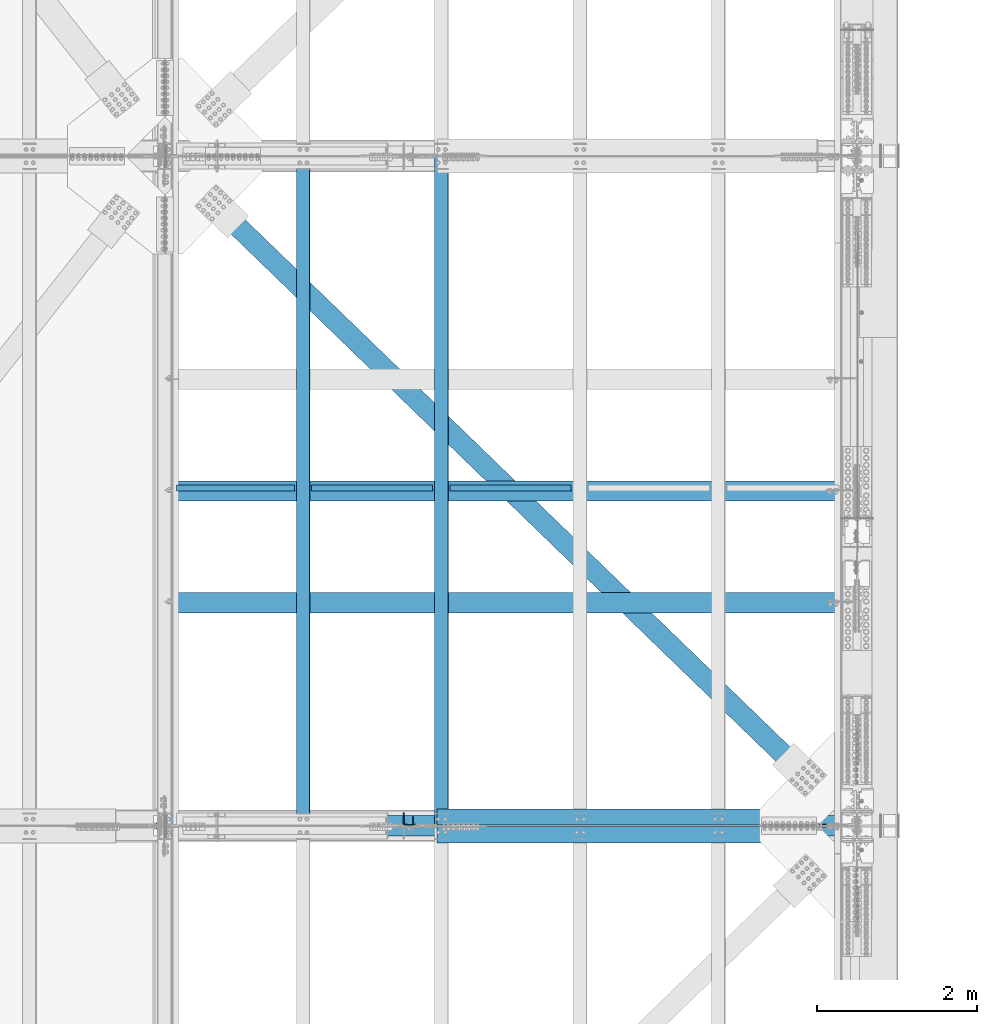
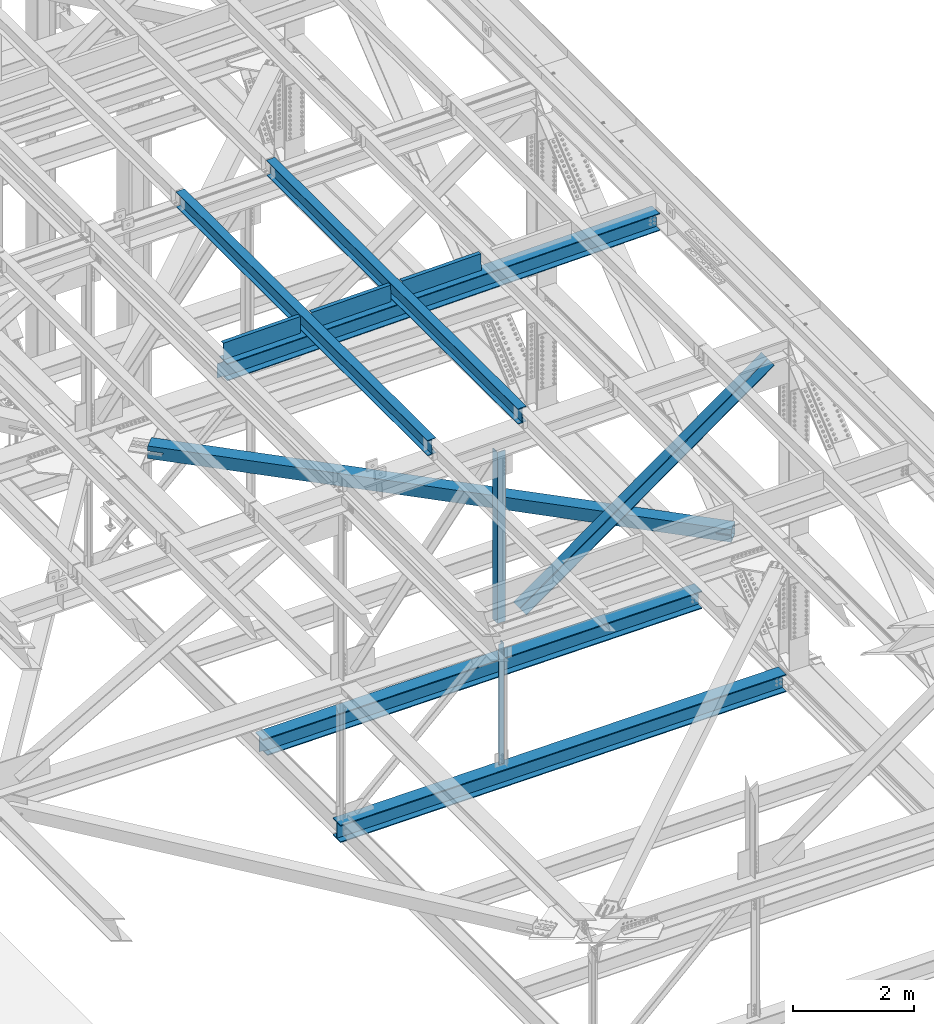
# One storey, part 1976 of 3843: 11 beams, 2 members, 13 elements without a shape of their own.
"""IFC2X3 building model written with IfcOpenShell, lengths in millimetres."""

from ifc_helpers import new_model, si_unit, frame, origin_with_axes, place, context, subcontext, project, spatial, faceted_brep, material, type_object, element, aggregate, save


model = new_model("IFC2X3")

# Units and contexts
model_context = context("Model", 3, precision=1e-05, world=origin_with_axes())
body_context = subcontext(model_context, "Body", "Model", "MODEL_VIEW")
ifc_project = project(units=[si_unit("LENGTHUNIT", "METRE", prefix="MILLI"), si_unit("AREAUNIT", "SQUARE_METRE"), si_unit("VOLUMEUNIT", "CUBIC_METRE"), si_unit("MASSUNIT", "GRAM", prefix="KILO"), si_unit("TIMEUNIT", "SECOND"), si_unit("PLANEANGLEUNIT", "RADIAN"), si_unit("SOLIDANGLEUNIT", "STERADIAN"), si_unit("THERMODYNAMICTEMPERATUREUNIT", "DEGREE_CELSIUS"), si_unit("LUMINOUSINTENSITYUNIT", "LUMEN")], contexts=[model_context])

# Site, building, storey
site_placement = place(None, origin_with_axes())
site = spatial("IfcSite", under=ifc_project, at=site_placement, CompositionType="ELEMENT")
building_placement = place(site_placement, origin_with_axes())
building = spatial("IfcBuilding", under=site, at=building_placement, Name="Undefined", CompositionType="ELEMENT")
storey_placement = place(building_placement, origin_with_axes())
storey = spatial("IfcBuildingStorey", under=building, at=storey_placement, Name="Undefined", CompositionType="ELEMENT", Elevation=0.0)

# Assembly, beam
assembly_1_placement = place(storey_placement, origin_with_axes())
assembly_1 = element("IfcElementAssembly", 1, at=assembly_1_placement, inside=storey, Name="ANGLE", AssemblyPlace="NOTDEFINED", PredefinedType="RIGID_FRAME")
ifc_material_1 = material(Name="STEEL/A572-50")
beam_type_1 = type_object("IfcBeamType", Name="L4X4X3/8", PredefinedType="NOTDEFINED")
beam_1_placement = place(assembly_1_placement, frame((80060.8000000188, 67332.225, 42332.0264524968), z_axis=(-1.0, 0.0, 0.0), x_axis=(0.0, 0.0, -1.0)))
beam_1 = element("IfcBeam", 2, at=beam_1_placement, type_object=beam_type_1, material=ifc_material_1, Name="ANGLE", ObjectType="L4X4X3/8", context=body_context, shape_type="Brep", body=[
    faceted_brep([(217.533433356046, 50.8000000000029, -50.8000000000029), (217.533433356046, 50.8000000000029, 50.8000000000029), (2656.88172797261, 50.8000000000029, 50.8000000000029), (2656.88172797261, 50.8000000000029, -50.8000000000029), (217.533433356046, 41.2749999999942, 50.8000000000029), (2656.88172797261, 41.2749999999942, 50.8000000000029), (217.533433356046, 41.2749999999942, -41.2749999999942), (2656.88172797261, 41.2749999999942, -41.2749999999942), (217.533433356046, -50.8000000000029, -41.2749999999942), (2656.88172797261, -50.8000000000029, -41.2749999999942), (217.533433356046, -50.8000000000029, -50.8000000000029), (2656.88172797261, -50.8000000000029, -50.8000000000029)], [[[0, 1, 2, 3]], [[1, 4, 5, 2]], [[4, 6, 7, 5]], [[6, 8, 9, 7]], [[8, 10, 11, 9]], [[10, 0, 3, 11]], [[5, 7, 9, 11, 3, 2]], [[10, 8, 6, 4, 1, 0]]]),
])
aggregate(assembly_1, [beam_1])

assembly_2_placement = place(storey_placement, origin_with_axes())
assembly_2 = element("IfcElementAssembly", 3, at=assembly_2_placement, inside=storey, Name="BEAM", AssemblyPlace="NOTDEFINED", PredefinedType="RIGID_FRAME")
ifc_material_2 = material(Name="STEEL/A992")
beam_type_2 = type_object("IfcBeamType", Name="W12X26", PredefinedType="NOTDEFINED")
beam_2_placement = place(assembly_2_placement, frame((80463.9094464825, 67272.235581982, 46586.9680416804), z_axis=(-0.021152098224542, 0.00215704300087236, 0.999773942402077), x_axis=(5.99999983432721e-09, 0.999997672538073, -0.00215752599900297)))
beam_2 = element("IfcBeam", 4, at=beam_2_placement, type_object=beam_type_2, material=ifc_material_2, Name="BEAM", ObjectType="W12X26", context=body_context, shape_type="Brep", body=[
    faceted_brep([(12.7037963889888, 82.550000000585, -155.57500000039), (12.6832505025814, 82.550000000585, -146.050000000381), (8343.90264109008, 82.5500000384782, -146.049999975839), (8343.92318697649, 82.5500000384927, -155.574999975855), (12.6796285968449, 3.17500000013388, -146.050000000163), (8343.89901918435, 3.17500003804162, -146.049999975628), (12.04955474702, 3.17500000003201, 146.050000000221), (8343.26894533455, 3.17500003793975, 146.050000024748), (12.0531766527711, 82.5500000004977, 146.049999999996), (8343.27256724026, 82.5500000384054, 146.050000024537), (12.0326307663636, 82.5500000004977, 155.575000000012), (8343.25202135387, 82.5500000383909, 155.575000024546), (12.0250972024223, -82.550000000454, 155.575000000463), (8343.24448778994, -82.5499999625608, 155.575000025005), (12.0456430888298, -82.550000000454, 146.050000000461), (8343.26503367635, -82.5499999625463, 146.050000024989), (12.0492649945663, -3.17500000000291, 146.050000000236), (8343.26865558207, -3.17499996210972, 146.05000002477), (12.6793388443766, -3.1749999999156, -146.050000000141), (8343.89872943189, -3.17499996200786, -146.049999975599), (12.6757169386547, -82.5500000003522, -146.049999999923), (8343.89510752616, -82.549999962459, -146.049999975388), (12.6962628250476, -82.5500000003522, -155.574999999924), (8343.91565341257, -82.5499999624444, -155.574999975397)], [[[0, 1, 2, 3]], [[1, 4, 5, 2]], [[4, 6, 7, 5]], [[6, 8, 9, 7]], [[8, 10, 11, 9]], [[10, 12, 13, 11]], [[12, 14, 15, 13]], [[14, 16, 17, 15]], [[16, 18, 19, 17]], [[18, 20, 21, 19]], [[20, 22, 23, 21]], [[22, 0, 3, 23]], [[5, 7, 9, 11, 13, 15, 17, 19, 21, 23, 3, 2]], [[22, 20, 18, 16, 14, 12, 10, 8, 6, 4, 1, 0]]]),
])
aggregate(assembly_2, [beam_2])

assembly_3_placement = place(storey_placement, origin_with_axes())
assembly_3 = element("IfcElementAssembly", 5, at=assembly_3_placement, inside=storey, Name="BEAM", AssemblyPlace="NOTDEFINED", PredefinedType="RIGID_FRAME")
beam_3_placement = place(assembly_3_placement, frame((78736.709446509, 67272.2368257242, 46553.2797616428), z_axis=(-0.02115209757931, 0.00216448800069338, 0.999773926325192), x_axis=(0.0, 0.999997653701546, -0.00216623899934971)))
beam_3 = element("IfcBeam", 6, at=beam_3_placement, type_object=beam_type_2, material=ifc_material_2, Name="BEAM", ObjectType="W12X26", context=body_context, shape_type="Brep", body=[
    faceted_brep([(12.7037963889888, 82.550000000585, -155.57500000039), (12.683193207602, 82.5500000002357, -146.050000000549), (8343.90271783868, 82.5500000001048, -146.049999994), (8343.92333463172, 82.5500000000757, -155.574999994024), (12.6795583240309, 3.17499999979918, -146.050000000425), (8343.8990829551, 3.17499999965366, -146.049999993877), (12.0471441895206, 3.17500000087603, 146.050000000134), (8343.26667870262, 3.1750000386819, 146.050000029725), (12.0507795210287, 82.5500000013417, 146.049999999879), (8343.27031403412, 82.550000039133, 146.050000029471), (12.0301574891928, 82.5500000013853, 155.574999999881), (8343.2496920023, 82.5500000391767, 155.575000029479), (12.0225959997188, -82.5499999995372, 155.575000000405), (8343.24213051282, -82.5499999617459, 155.575000029996), (12.0432180315256, -82.5499999995955, 146.05000000041), (8343.26275254463, -82.5499999618041, 146.050000030002), (12.0468533630192, -3.17499999914435, 146.050000000156), (8343.26638787612, -3.17499996136758, 146.050000029747), (12.6792675333563, -3.17500000025029, -146.050000000425), (8343.89879216443, -3.17500000038126, -146.049999993869), (12.6756326497853, -82.5500000006869, -146.050000000301), (8343.89516152057, -82.5499999634485, -146.049999970179), (12.6962628250476, -82.5500000003522, -155.574999999924), (8343.9157740739, -82.5500000008324, -155.574999993776)], [[[0, 1, 2, 3]], [[1, 4, 5, 2]], [[4, 6, 7, 5]], [[6, 8, 9, 7]], [[8, 10, 11, 9]], [[10, 12, 13, 11]], [[12, 14, 15, 13]], [[14, 16, 17, 15]], [[16, 18, 19, 17]], [[18, 20, 21, 19]], [[20, 22, 23, 21]], [[22, 0, 3, 23]], [[5, 7, 9, 11, 13, 15, 17, 19, 21, 23, 3, 2]], [[22, 20, 18, 16, 14, 12, 10, 8, 6, 4, 1, 0]]]),
])
aggregate(assembly_3, [beam_3])

assembly_4_placement = place(storey_placement, origin_with_axes())
assembly_4 = element("IfcElementAssembly", 7, at=assembly_4_placement, inside=storey, Name="BENT_PLATE", AssemblyPlace="NOTDEFINED", PredefinedType="RIGID_FRAME")
ifc_material_3 = material(Name="STEEL/A36")
beam_type_3 = type_object("IfcBeamType", PredefinedType="NOTDEFINED")
beam_4_placement = place(assembly_4_placement, frame((77895.7314779937, 71454.9625000036, 46351.471686772), z_axis=(-0.999843950547446, 0.0, -0.0176656319920002), x_axis=(-0.0176656319919986, 0.0, 0.999843950547446)))
beam_4 = element("IfcBeam", 8, at=beam_4_placement, type_object=beam_type_3, material=ifc_material_3, Name="BENT_PLATE", context=body_context, shape_type="Brep", body=[
    faceted_brep([(2.31375452131033e-09, -4.76249999999709, -736.599999997517), (-2.30647856369615e-09, -4.76249999999709, 736.599999997474), (-2.30647856369615e-09, 4.76249999999709, 736.599999997474), (2.31375452131033e-09, 4.76249999999709, -736.599999997517), (327.024999947338, 4.76250000002619, 736.600000004051), (327.024999981979, 4.76250000002619, -736.600000004313), (336.549999981966, -4.76249999996799, -736.600000004328), (336.549999947325, -4.76249999996799, 736.600000004051), (327.024999959613, 71.4375000200889, 736.600000005245), (327.024999969712, 71.4375000446889, -736.60000000312), (336.549999959585, 71.4375000200962, 736.600000005245), (336.549999969691, 71.4375000446962, -736.600000003134)], [[[0, 1, 2, 3]], [[3, 2, 4, 5]], [[1, 0, 6, 7]], [[5, 4, 8, 9]], [[4, 2, 1, 7, 10, 8]], [[7, 6, 11, 10]], [[6, 0, 3, 5, 9, 11]], [[10, 11, 9, 8]]]),
])
aggregate(assembly_4, [beam_4])

assembly_5_placement = place(storey_placement, origin_with_axes())
assembly_5 = element("IfcElementAssembly", 9, at=assembly_5_placement, inside=storey, Name="BENT_PLATE", AssemblyPlace="NOTDEFINED", PredefinedType="RIGID_FRAME")
beam_5_placement = place(assembly_5_placement, frame((79602.4343909603, 71454.9625000037, 46381.6467390228), z_axis=(-0.999843950547446, 0.0, -0.0176656319920002), x_axis=(-0.0176656319919986, 0.0, 0.999843950547446)))
beam_5 = element("IfcBeam", 10, at=beam_5_placement, type_object=beam_type_3, material=ifc_material_3, Name="BENT_PLATE", context=body_context, shape_type="Brep", body=[
    faceted_brep([(2.38651409745216e-09, -4.76249999999709, -755.649999997448), (-2.37923813983798e-09, -4.76249999999709, 755.649999997433), (-2.37923813983798e-09, 4.76249999999709, 755.649999997433), (2.38651409745216e-09, 4.76249999999709, -755.649999997448), (327.024999945941, 4.76250000002619, 755.650000004171), (327.024999981295, 4.76250000002619, -755.650000004418), (336.549999981282, -4.76249999996799, -755.650000004447), (336.549999945928, -4.76249999996799, 755.650000004156), (327.024999958514, 71.4375000207219, 755.650000005364), (327.024999968708, 71.4375000458094, -755.650000003239), (336.549999958501, 71.4375000207219, 755.650000005349), (336.549999968687, 71.4375000458094, -755.650000003254)], [[[0, 1, 2, 3]], [[3, 2, 4, 5]], [[1, 0, 6, 7]], [[5, 4, 8, 9]], [[4, 2, 1, 7, 10, 8]], [[7, 6, 11, 10]], [[6, 0, 3, 5, 9, 11]], [[10, 11, 9, 8]]]),
])
aggregate(assembly_5, [beam_5])

assembly_6_placement = place(storey_placement, origin_with_axes())
assembly_6 = element("IfcElementAssembly", 11, at=assembly_6_placement, inside=storey, Name="BENT_PLATE", AssemblyPlace="NOTDEFINED", PredefinedType="RIGID_FRAME")
beam_6_placement = place(assembly_6_placement, frame((81331.2218909603, 71454.9625000037, 46411.7688442907), z_axis=(-0.999843950547446, 0.0, -0.0176656319920002), x_axis=(-0.0176656319919986, 0.0, 0.999843950547446)))
beam_6 = element("IfcBeam", 12, at=beam_6_placement, type_object=beam_type_3, material=ifc_material_3, Name="BENT_PLATE", context=body_context, shape_type="Brep", body=[
    faceted_brep([(2.38651409745216e-09, -4.76249999999709, -755.649999997448), (-2.37923813983798e-09, -4.76249999999709, 755.649999997433), (-2.37923813983798e-09, 4.76249999999709, 755.649999997433), (2.38651409745216e-09, 4.76249999999709, -755.649999997448), (327.024999945941, 4.76250000002619, 755.650000004171), (327.024999981295, 4.76250000002619, -755.650000004418), (336.549999981282, -4.76249999996799, -755.650000004447), (336.549999945928, -4.76249999996799, 755.650000004156), (327.024999958514, 71.4375000207219, 755.650000005364), (327.024999968708, 71.4375000458094, -755.650000003239), (336.549999958501, 71.4375000207219, 755.650000005349), (336.549999968687, 71.4375000458094, -755.650000003254)], [[[0, 1, 2, 3]], [[3, 2, 4, 5]], [[1, 0, 6, 7]], [[5, 4, 8, 9]], [[4, 2, 1, 7, 10, 8]], [[7, 6, 11, 10]], [[6, 0, 3, 5, 9, 11]], [[10, 11, 9, 8]]]),
])
aggregate(assembly_6, [beam_6])

# Assembly, member
assembly_7_placement = place(storey_placement, origin_with_axes())
assembly_7 = element("IfcElementAssembly", 13, at=assembly_7_placement, inside=storey, Name="ANGLE", AssemblyPlace="NOTDEFINED", PredefinedType="RIGID_FRAME")
member_type = type_object("IfcMemberType", Name="L8X8X1/2", PredefinedType="NOTDEFINED")
member_1_placement = place(assembly_7_placement, frame((85648.8, 67383.025, 46330.0142937513), z_axis=(0.0, 1.0, 0.0), x_axis=(-0.813281705951066, 0.0, -0.581870145964995)))
member_1 = element("IfcMember", 14, at=member_1_placement, type_object=member_type, material=ifc_material_1, Name="ANGLE", ObjectType="L8X8X1/2", context=body_context, shape_type="Brep", body=[
    faceted_brep([(538.706939724565, 101.60000000055, -101.600000000006), (538.706939724565, 101.60000000055, 101.600000000006), (6370.26540610321, 101.600000005526, 101.600000000006), (6370.26540610321, 101.600000005526, -101.600000000006), (538.70693972458, 88.9000000005308, 101.600000000006), (6370.26540610321, 88.9000000055294, 101.600000000006), (538.70693972458, 88.9000000005308, -88.8999999999942), (6370.26540610321, 88.9000000055294, -88.8999999999942), (538.70693972458, -101.599999999615, -88.8999999999942), (6370.26540610321, -101.599999994638, -88.8999999999942), (538.70693972458, -101.599999999615, -101.600000000006), (6370.26540610321, -101.599999994638, -101.600000000006)], [[[0, 1, 2, 3]], [[1, 4, 5, 2]], [[4, 6, 7, 5]], [[6, 8, 9, 7]], [[8, 10, 11, 9]], [[10, 0, 3, 11]], [[5, 7, 9, 11, 3, 2]], [[10, 8, 6, 4, 1, 0]]]),
])
aggregate(assembly_7, [member_1])

assembly_8_placement = place(storey_placement, origin_with_axes())
assembly_8 = element("IfcElementAssembly", 15, at=assembly_8_placement, inside=storey, Name="ANGLE", AssemblyPlace="NOTDEFINED", PredefinedType="RIGID_FRAME")
member_2_placement = place(assembly_8_placement, frame((80060.7999999991, 67160.775, 42332.0264524769), z_axis=(0.0, -1.0, 0.0), x_axis=(0.813281705951069, 0.0, 0.58187014596499)))
member_2 = element("IfcMember", 16, at=member_2_placement, type_object=member_type, material=ifc_material_1, Name="ANGLE", ObjectType="L8X8X1/2", context=body_context, shape_type="Brep", body=[
    faceted_brep([(500.662535532232, 101.599999999667, -101.600000000006), (500.662535532232, 101.599999999667, 101.600000000006), (6332.22100191088, 101.599999994676, 101.600000000006), (6332.22100191088, 101.599999994676, -101.600000000006), (500.662535532232, 88.8999999996558, 101.600000000006), (6332.22100191086, 88.8999999946645, 101.600000000006), (500.662535532232, 88.8999999996558, -88.8999999999942), (6332.22100191086, 88.8999999946645, -88.8999999999942), (500.662535532232, -101.600000000504, -88.8999999999942), (6332.22100191086, -101.600000005496, -88.8999999999942), (500.662535532232, -101.600000000504, -101.600000000006), (6332.22100191086, -101.600000005496, -101.600000000006)], [[[0, 1, 2, 3]], [[1, 4, 5, 2]], [[4, 6, 7, 5]], [[6, 8, 9, 7]], [[8, 10, 11, 9]], [[10, 0, 3, 11]], [[5, 7, 9, 11, 3, 2]], [[10, 8, 6, 4, 1, 0]]]),
])
aggregate(assembly_8, [member_2])

# Assembly, beam
assembly_9_placement = place(storey_placement, origin_with_axes())
assembly_9 = element("IfcElementAssembly", 17, at=assembly_9_placement, inside=storey, Name="ANGLE", AssemblyPlace="NOTDEFINED", PredefinedType="RIGID_FRAME")
beam_type_4 = type_object("IfcBeamType", Name="L6X6X1/2", PredefinedType="NOTDEFINED")
beam_7_placement = place(assembly_9_placement, frame((80060.800000138, 67357.625, 46226.8738706244), z_axis=(0.0, 1.0, 0.0), x_axis=(0.0, 0.0, -1.0)))
beam_7 = element("IfcBeam", 18, at=beam_7_placement, type_object=beam_type_4, material=ifc_material_1, Name="ANGLE", ObjectType="L6X6X1/2", context=body_context, shape_type="Brep", body=[
    faceted_brep([(224.359237620578, 76.1999999999971, -76.1999999999971), (224.359237620578, 76.1999999999971, 76.1999999999971), (3686.13865215448, 76.1999999999971, 76.1999999999971), (3686.13865215448, 76.1999999999971, -76.1999999999971), (224.359237620578, 63.5, 76.1999999999971), (3686.13865215448, 63.5, 76.1999999999971), (224.359237620578, 63.5, -63.5), (3686.13865215448, 63.5, -63.5), (224.359237620578, -76.1999999999971, -63.5), (3686.13865215448, -76.1999999999971, -63.5), (224.359237620578, -76.1999999999971, -76.1999999999971), (3686.13865215448, -76.1999999999971, -76.1999999999971)], [[[0, 1, 2, 3]], [[1, 4, 5, 2]], [[4, 6, 7, 5]], [[6, 8, 9, 7]], [[8, 10, 11, 9]], [[10, 0, 3, 11]], [[5, 7, 9, 11, 3, 2]], [[10, 8, 6, 4, 1, 0]]]),
])
aggregate(assembly_9, [beam_7])

assembly_10_placement = place(storey_placement, origin_with_axes())
assembly_10 = element("IfcElementAssembly", 19, at=assembly_10_placement, inside=storey, AssemblyPlace="NOTDEFINED", PredefinedType="RIGID_FRAME")
ifc_material_4 = material()
beam_type_5 = type_object("IfcBeamType", Name="HSS10X10X3/4", PredefinedType="NOTDEFINED")
beam_8_placement = place(assembly_10_placement, frame((77012.8000000074, 75628.4999999928, 42246.5510007858), z_axis=(0.695386222991622, 0.718636208991341, 0.0), x_axis=(0.718636212924518, -0.695386218926941, 0.0)))
beam_8 = element("IfcBeam", 20, at=beam_8_placement, type_object=beam_type_5, material=ifc_material_4, ObjectType="HSS10X10X3/4", context=body_context, shape_type="Brep", body=[
    faceted_brep([(1270.43308024336, -26.9881270980623, -107.949999999662), (1270.4330802165, -26.9881270980623, -126.999999999563), (1018.02056844692, -26.9881270980623, -126.999999999491), (1018.02056847385, -26.9881270980623, -107.949999999604), (1275.90066992921, -25.900555889777, -107.949999999662), (1275.90066990235, -25.900555889777, -126.999999999549), (1280.53586864922, -22.8034151225365, -107.949999999662), (1280.53586862235, -22.8034151225365, -126.999999999563), (1283.63300941644, -18.1682164024896, -107.949999999662), (1283.63300938957, -18.1682164024896, -126.999999999563), (1284.72058062471, -12.7006267165925, -107.949999999662), (1284.72058059784, -12.7006267165925, -126.999999999563), (1283.63300941644, -7.23303779363778, -107.949999999662), (1283.63300938957, -7.23303779363778, -126.999999999563), (1280.53586864922, -2.59783907359088, -107.949999999662), (1280.53586862235, -2.59783907359088, -126.999999999563), (1275.90066992921, 0.499301693649613, -107.949999999662), (1275.90066990235, 0.499301693649613, -126.999999999549), (1270.43308024336, 1.58687290193484, -107.949999999662), (1270.4330802165, 1.58687290193484, -126.999999999563), (1018.02056847385, 1.58687290193484, -107.949999999604), (1018.02056844692, 1.58687290193484, -126.999999999491), (10732.8985698615, -26.9864992141593, -107.950000001641), (10732.8985697537, -26.9864992141593, -127.000000001528), (10727.4309800678, -25.898928005874, -127.000000001528), (10727.4309801757, -25.898928005874, -107.950000001641), (10722.7957813478, -22.8017872386336, -127.000000001513), (10722.7957814556, -22.8017872386336, -107.950000001641), (10719.6986405806, -18.1665885185867, -127.000000001528), (10719.6986406884, -18.1665885185867, -107.950000001641), (10718.6110693723, -12.6989988326895, -127.000000001513), (10718.6110694802, -12.6989988326895, -107.950000001641), (10719.6986405806, -7.23140990973479, -127.000000001528), (10719.6986406884, -7.23140990973479, -107.950000001641), (10722.7957813478, -2.59621118968789, -127.000000001513), (10722.7957814556, -2.59621118968789, -107.950000001641), (10727.4309800678, 0.500929577552597, -127.000000001528), (10727.4309801757, 0.500929577552597, -107.950000001641), (10732.8985697537, 1.58850078583782, -127.000000001528), (10732.8985698615, 1.58850078583782, -107.950000001641), (10985.3110824267, 1.58850078583782, -127.000000001572), (10985.3110824267, 1.58850078583782, -107.950000001685), (1018.02056851258, 127.0, -126.999999995736), (1018.02056851302, 127.0, 127.000000003467), (10985.3110826023, 127.0, 126.99999994025), (10985.3110826049, 127.0, -127.000000059677), (10732.8985711915, -26.9864992141593, 126.999999997061), (10732.8985710836, -26.9864992141593, 107.949999997174), (10727.4309813978, -25.898928005874, 107.949999997159), (10727.4309815056, -25.898928005874, 126.999999997061), (10722.7957826777, -22.8017872386336, 107.949999997174), (10722.7957827856, -22.8017872386336, 126.999999997075), (10719.6986419105, -18.1665885185867, 107.949999997189), (10719.6986420184, -18.1665885185867, 126.999999997075), (10718.6110707023, -12.6989988326895, 107.949999997159), (10718.6110708101, -12.6989988326895, 126.999999997061), (10719.6986419105, -7.23140990973479, 107.949999997189), (10719.6986420184, -7.23140990973479, 126.999999997075), (10722.7957826777, -2.59621118968789, 107.949999997174), (10722.7957827856, -2.59621118968789, 126.999999997075), (10727.4309813978, 0.500929577552597, 107.949999997159), (10727.4309815056, 0.500929577552597, 126.999999997061), (10732.8985710836, 1.58850078583782, 107.949999997174), (10732.8985711915, 1.58850078583782, 126.999999997061), (10985.3110824267, 1.58850078583782, 107.94999999713), (10985.3110824267, 1.58850078583782, 126.999999997002), (10985.3110826025, 107.949999999997, 107.949999940247), (10985.3110826047, 107.949999999997, -107.950000059674), (1018.02056851298, 107.949999999997, 107.950000003533), (1018.02056851263, 107.949999999997, -107.949999995799), (1018.02056877914, 1.58687290193484, 107.949999999197), (1018.02056880608, 1.58687290193484, 126.999999999098), (1270.43308054782, 1.58687290193484, 107.949999999139), (1270.43308057469, 1.58687290193484, 126.99999999904), (1275.90067023368, 0.499301693649613, 107.949999999139), (1275.90067026053, 0.499301693649613, 126.99999999904), (1280.53586895368, -2.59783907359088, 107.949999999139), (1280.53586898055, -2.59783907359088, 126.99999999904), (1283.63300972091, -7.23303779363778, 107.949999999139), (1283.63300974777, -7.23303779363778, 126.99999999904), (1284.72058092917, -12.7006267165925, 107.949999999139), (1284.72058095605, -12.7006267165925, 126.99999999904), (1283.63300972091, -18.1682164024896, 107.949999999139), (1283.63300974777, -18.1682164024896, 126.99999999904), (1280.53586895368, -22.8034151225365, 107.949999999139), (1280.53586898055, -22.8034151225365, 126.99999999904), (1275.90067023368, -25.900555889777, 107.949999999139), (1275.90067026053, -25.900555889777, 126.99999999904), (1270.43308054782, -26.9881270980623, 107.949999999139), (1270.43308057469, -26.9881270980623, 126.99999999904), (1018.02056877914, -26.9881270980623, 107.949999999197), (1018.02056880608, -26.9881270980623, 126.999999999098), (1018.02056851298, -107.949999999997, 107.950000003533), (1018.02056851263, -107.949999999997, -107.949999995799), (1018.02056851258, -127.0, -126.999999995736), (1018.02056851302, -127.0, 127.000000003467), (10985.3110826023, -127.0, 126.99999994025), (10985.3110824267, -26.9864992141593, 126.999999997002), (10985.3110824267, -26.9864992141593, 107.94999999713), (10985.3110826025, -107.949999999997, 107.949999940247), (10985.3110826047, -107.949999999997, -107.950000059674), (10985.3110824267, -26.9864992141593, -107.950000001685), (10985.3110824267, -26.9864992141593, -127.000000001572), (10985.3110826049, -127.0, -127.000000059677)], [[[0, 1, 2, 3]], [[4, 5, 1, 0]], [[6, 7, 5, 4]], [[8, 9, 7, 6]], [[10, 11, 9, 8]], [[12, 13, 11, 10]], [[14, 15, 13, 12]], [[16, 17, 15, 14]], [[18, 19, 17, 16]], [[20, 21, 19, 18]], [[22, 23, 24, 25]], [[25, 24, 26, 27]], [[27, 26, 28, 29]], [[29, 28, 30, 31]], [[31, 30, 32, 33]], [[33, 32, 34, 35]], [[35, 34, 36, 37]], [[37, 36, 38, 39]], [[39, 38, 40, 41]], [[42, 43, 44, 45]], [[46, 47, 48, 49]], [[49, 48, 50, 51]], [[51, 50, 52, 53]], [[53, 52, 54, 55]], [[55, 54, 56, 57]], [[57, 56, 58, 59]], [[59, 58, 60, 61]], [[61, 60, 62, 63]], [[63, 62, 64, 65]], [[66, 67, 41, 40, 45, 44, 65, 64]], [[68, 69, 67, 66]], [[43, 42, 21, 20, 69, 68, 70, 71]], [[71, 70, 72, 73]], [[73, 72, 74, 75]], [[75, 74, 76, 77]], [[77, 76, 78, 79]], [[79, 78, 80, 81]], [[81, 80, 82, 83]], [[83, 82, 84, 85]], [[85, 84, 86, 87]], [[87, 86, 88, 89]], [[89, 88, 90, 91]], [[92, 93, 3, 2, 94, 95, 91, 90]], [[46, 49, 51, 53, 55, 57, 59, 61, 63, 65, 44, 43, 71, 73, 75, 77, 79, 81, 83, 85, 87, 89, 91, 95, 96, 97]], [[47, 46, 97, 98]], [[92, 90, 88, 86, 84, 82, 80, 78, 76, 74, 72, 70, 68, 66, 64, 62, 60, 58, 56, 54, 52, 50, 48, 47, 98, 99]], [[93, 92, 99, 100]], [[22, 25, 27, 29, 31, 33, 35, 37, 39, 41, 67, 69, 20, 18, 16, 14, 12, 10, 8, 6, 4, 0, 3, 93, 100, 101]], [[23, 22, 101, 102]], [[94, 2, 1, 5, 7, 9, 11, 13, 15, 17, 19, 21, 42, 45, 40, 38, 36, 34, 32, 30, 28, 26, 24, 23, 102, 103]], [[95, 94, 103, 96]], [[102, 101, 100, 99, 98, 97, 96, 103]]]),
])
aggregate(assembly_10, [beam_8])

assembly_11_placement = place(storey_placement, origin_with_axes())
assembly_11 = element("IfcElementAssembly", 21, at=assembly_11_placement, inside=storey, Name="BEAM", AssemblyPlace="NOTDEFINED", PredefinedType="RIGID_FRAME")
beam_type_6 = type_object("IfcBeamType", Name="W14X61", PredefinedType="NOTDEFINED")
beam_9_placement = place(assembly_11_placement, frame((77012.7999994663, 71450.2, 46159.0848309841), z_axis=(-0.0176668689945437, 0.0, 0.999843928690838), x_axis=(0.999843928690838, 0.0, 0.0176668689945373)))
beam_9 = element("IfcBeam", 22, at=beam_9_placement, type_object=beam_type_6, material=ifc_material_2, Name="BEAM", ObjectType="W14X61", context=body_context, shape_type="Brep", body=[
    faceted_brep([(15.7065018058202, -4.76249999999709, -144.462499994625), (15.7065018058202, 4.76249999999709, -144.462499994625), (129.44549134525, 4.76249999999709, -144.462499994333), (129.44549134525, -4.76249999999709, -144.462499994333), (134.305570863231, 4.76249999999709, -145.429229916925), (134.305570863231, -4.76249999999709, -145.429229916925), (138.425747331334, 4.76249999999709, -148.182243817413), (138.425747331334, -4.76249999999709, -148.182243817413), (141.178761231786, 4.76249999999709, -152.302420285603), (141.178761231786, -4.76249999999709, -152.302420285603), (142.14549115437, -4.76249999999709, -157.162499803686), (142.14549115437, 4.76249999999709, -157.162499803686), (142.145491154384, 4.76249999999709, -160.337500000191), (142.145491154384, 127.0, -160.337500000191), (142.145491154413, 127.0, -176.212500000234), (142.145491154413, -127.0, -176.212500000234), (142.145491154384, -127.0, -160.337500000191), (142.145491154384, -4.76249999999709, -160.337500000191), (8418.30073252501, -127.0, 160.337500017275), (8418.30073252501, -127.0, 176.212500017326), (142.145491153773, -127.0, 176.212500000802), (142.145491153802, -127.0, 160.337500000758), (8418.30073252501, 127.0, 176.212500017326), (142.145491153773, 127.0, 176.212500000802), (8418.30073252501, 127.0, 160.337500017275), (142.145491153802, 127.0, 160.337500000758), (8418.30073252501, 4.76249999999709, 160.337500017275), (142.145491153802, 4.76249999999709, 160.337500000758), (129.445491344712, -4.76249999999709, 144.462500008187), (129.445491344712, 4.76249999999709, 144.462500008187), (20.811698704827, 4.76249999999709, 144.462500007969), (20.811698704827, -4.76249999999709, 144.462500007969), (134.305570862693, -4.76249999999709, 145.429229930793), (134.305570862693, 4.76249999999709, 145.429229930793), (138.425747330795, -4.76249999999709, 148.182243831303), (138.425747330795, 4.76249999999709, 148.182243831303), (141.178761231233, -4.76249999999709, 152.3024202995), (141.178761231233, 4.76249999999709, 152.3024202995), (142.145491153788, -4.76249999999709, 157.162499817576), (142.145491153788, 4.76249999999709, 157.162499817576), (142.145491153802, -4.76249999999709, 160.337500000758), (8418.30073252501, -4.76249999999709, 160.337500017275), (8418.30073252496, 4.76249999999709, -160.33749998366), (8418.30073252496, -4.76249999999709, -160.33749998366), (8418.30073252496, -127.0, -160.33749998366), (8418.30073252496, -127.0, -176.212499983711), (8418.30073252496, 127.0, -176.212499983711), (8418.30073252496, 127.0, -160.33749998366), (16.6353228174848, 4.76249999999709, -91.896533175066), (20.7093028076197, 4.76249999999709, 138.667476782393)], [[[0, 1, 2, 3]], [[3, 2, 4, 5]], [[5, 4, 6, 7]], [[7, 6, 8, 9]], [[10, 11, 12, 13, 14, 15, 16, 17]], [[9, 8, 11, 10]], [[18, 19, 20, 21]], [[19, 22, 23, 20]], [[22, 24, 25, 23]], [[24, 26, 27, 25]], [[28, 29, 30, 31]], [[32, 33, 29, 28]], [[34, 35, 33, 32]], [[36, 37, 35, 34]], [[38, 39, 37, 36]], [[20, 23, 25, 27, 39, 38, 40, 21]], [[41, 18, 21, 40]], [[42, 26, 24, 22, 19, 18, 41, 43, 44, 45, 46, 47]], [[44, 43, 17, 16]], [[45, 44, 16, 15]], [[46, 45, 15, 14]], [[47, 46, 14, 13]], [[42, 47, 13, 12]], [[6, 4, 2, 1, 48, 49, 30, 29, 33, 35, 37, 39, 27, 26, 42, 12, 11, 8]], [[31, 30, 49, 48, 1, 0]], [[43, 41, 40, 38, 36, 34, 32, 28, 31, 0, 3, 5, 7, 9, 10, 17]]]),
])
aggregate(assembly_11, [beam_9])

assembly_12_placement = place(storey_placement, origin_with_axes())
assembly_12 = element("IfcElementAssembly", 23, at=assembly_12_placement, inside=storey, Name="BEAM", AssemblyPlace="NOTDEFINED", PredefinedType="RIGID_FRAME")
beam_type_7 = type_object("IfcBeamType", Name="W14X68", PredefinedType="NOTDEFINED")
beam_10_placement = place(assembly_12_placement, frame((77011.4473046698, 70056.573444, 39446.1948542994), z_axis=(-0.00760796000040138, 0.0, 0.999971059053527), x_axis=(0.999971059053527, 0.0, 0.00760796000040691)))
beam_10 = element("IfcBeam", 24, at=beam_10_placement, type_object=beam_type_7, material=ifc_material_2, Name="BEAM", ObjectType="W14X68", context=body_context, shape_type="Brep", body=[
    faceted_brep([(18.4983381303318, -5.55624999999418, -146.050000002499), (18.4983381303318, 5.55624999999418, -146.050000002499), (94.4567786006228, 5.55624999999418, -146.050000000367), (94.4567786006228, -5.55624999999418, -146.050000000367), (99.31685811856, 5.55624999999418, -147.016729922914), (99.31685811856, -5.55624999999418, -147.016729922914), (103.437034586575, 5.55624999999418, -149.769743823359), (103.437034586575, -5.55624999999418, -149.769743823359), (106.190048486955, 5.55624999999418, -153.889920291484), (106.190048486955, -5.55624999999418, -153.889920291484), (107.156778409495, 5.55624999999418, -158.750000000058), (107.156778409495, -5.55624999999418, -158.750000000058), (107.156778409495, -127.0, -158.749999809508), (107.156778409495, 127.0, -158.750000000058), (107.156778409699, 127.0, -177.800000000119), (107.156778409699, -127.0, -177.800000000119), (20.8173114539532, 5.55624999999418, 158.750000000531), (20.8173114539532, 127.0, 158.750000000531), (8422.90422572797, 127.0, 158.750000030603), (8422.90422572797, 5.55624999999418, 158.750000030603), (20.9622472866904, 127.0, 177.800000000592), (8423.04916156067, 127.0, 177.800000030657), (20.9622472866904, -127.0, 177.800000000592), (8423.04916156067, -127.0, 177.800000030657), (20.8173114539532, -127.0, 158.750000000531), (8422.90422572797, -127.0, 158.750000030603), (20.8173114539532, -5.55624999999418, 158.750000000531), (8422.90422572797, -5.55624999999418, 158.750000030603), (8420.48862851586, 5.55624999999418, -158.749999970307), (8420.48862851586, -5.55624999999418, -158.749999970307), (8420.48862851586, -127.0, -158.749999970307), (8420.34369268313, -127.0, -177.799999970368), (8420.34369268313, 127.0, -177.799999970368), (8420.48862851586, 127.0, -158.749999970307), (18.8231855425256, 5.55624999999418, -103.352876138197), (20.5775811202911, 5.55624999999418, 127.240450080877)], [[[0, 1, 2, 3]], [[3, 2, 4, 5]], [[5, 4, 6, 7]], [[7, 6, 8, 9]], [[9, 8, 10, 11]], [[12, 11, 10, 13, 14, 15]], [[16, 17, 18, 19]], [[17, 20, 21, 18]], [[20, 22, 23, 21]], [[22, 24, 25, 23]], [[24, 26, 27, 25]], [[28, 19, 18, 21, 23, 25, 27, 29, 30, 31, 32, 33]], [[31, 30, 12, 15]], [[32, 31, 15, 14]], [[33, 32, 14, 13]], [[28, 33, 13, 10]], [[6, 4, 2, 1, 34, 35, 16, 19, 28, 10, 8]], [[26, 24, 22, 20, 17, 16, 35, 34, 1, 0]], [[29, 27, 26, 0, 3, 5, 7, 9, 11]], [[30, 29, 11, 12]]]),
])
aggregate(assembly_12, [beam_10])

assembly_13_placement = place(storey_placement, origin_with_axes())
assembly_13 = element("IfcElementAssembly", 25, at=assembly_13_placement, inside=storey, Name="BEAM", AssemblyPlace="NOTDEFINED", PredefinedType="RIGID_FRAME")
beam_11_placement = place(assembly_13_placement, frame((76909.770467847, 67271.9, 39446.1942531068), z_axis=(-0.00804011299814736, 0.0, 0.999967677769125), x_axis=(0.999967677769125, 0.0, 0.00804011299814388)))
beam_11 = element("IfcBeam", 26, at=beam_11_placement, type_object=beam_type_7, material=ifc_material_2, Name="BEAM", ObjectType="W14X68", context=body_context, shape_type="Brep", body=[
    faceted_brep([(1.06228981167078e-09, 127.0, -177.800000000105), (9.45874489843845e-10, 127.0, -158.750000000087), (8522.1286183715, 127.0, -158.750000015534), (8521.97544926811, 127.0, -177.800000015479), (9.45874489843845e-10, 5.55624999999418, -158.750000000087), (8522.1286183715, 5.55624999999418, -158.750000015534), (-9.74978320300579e-10, 5.55624999999418, 158.75000000008), (8524.68143676118, 5.55624999999418, 158.749999983498), (-9.74978320300579e-10, 127.0, 158.75000000008), (8524.68143676118, 127.0, 158.749999983498), (-1.07684172689915e-09, 127.0, 177.80000000009), (8524.83460586457, 127.0, 177.799999983443), (-1.07684172689915e-09, -127.0, 177.80000000009), (8524.83460586457, -127.0, 177.799999983443), (-9.74978320300579e-10, -127.0, 158.75000000008), (8524.68143676118, -127.0, 158.749999983498), (-9.74978320300579e-10, -5.55624999999418, 158.75000000008), (8524.68143676118, -5.55624999999418, 158.749999983498), (9.45874489843845e-10, -5.55624999999418, -158.750000000087), (8522.1286183715, -5.55624999999418, -158.750000015534), (9.45874489843845e-10, -127.0, -158.750000000087), (8522.1286183715, -127.0, -158.750000015534), (1.06228981167078e-09, -127.0, -177.800000000105), (8521.97544926811, -127.0, -177.800000015479)], [[[0, 1, 2, 3]], [[1, 4, 5, 2]], [[4, 6, 7, 5]], [[6, 8, 9, 7]], [[8, 10, 11, 9]], [[10, 12, 13, 11]], [[12, 14, 15, 13]], [[14, 16, 17, 15]], [[16, 18, 19, 17]], [[18, 20, 21, 19]], [[20, 22, 23, 21]], [[22, 0, 3, 23]], [[5, 7, 9, 11, 13, 15, 17, 19, 21, 23, 3, 2]], [[22, 20, 18, 16, 14, 12, 10, 8, 6, 4, 1, 0]]]),
])
aggregate(assembly_13, [beam_11])

save(model, "model.ifc")
